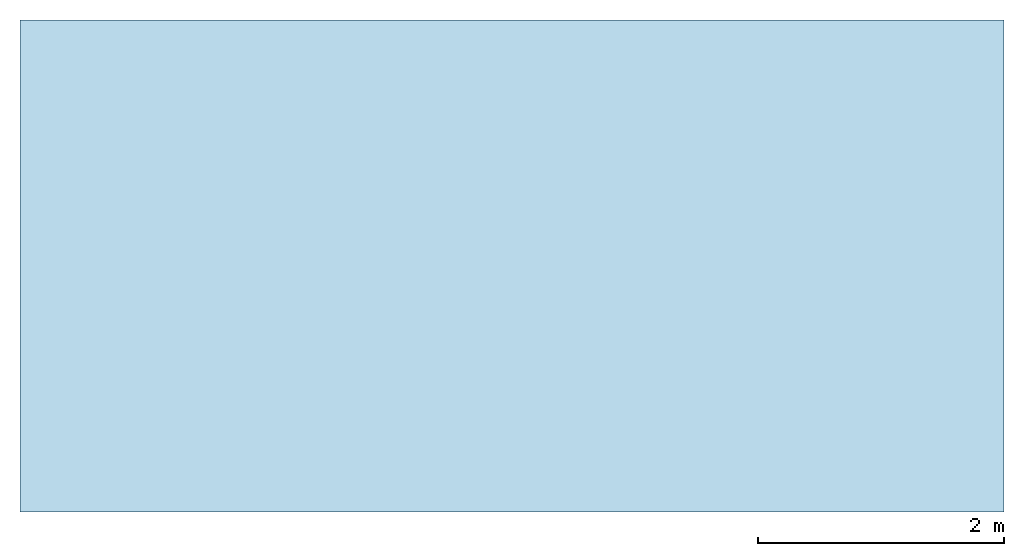
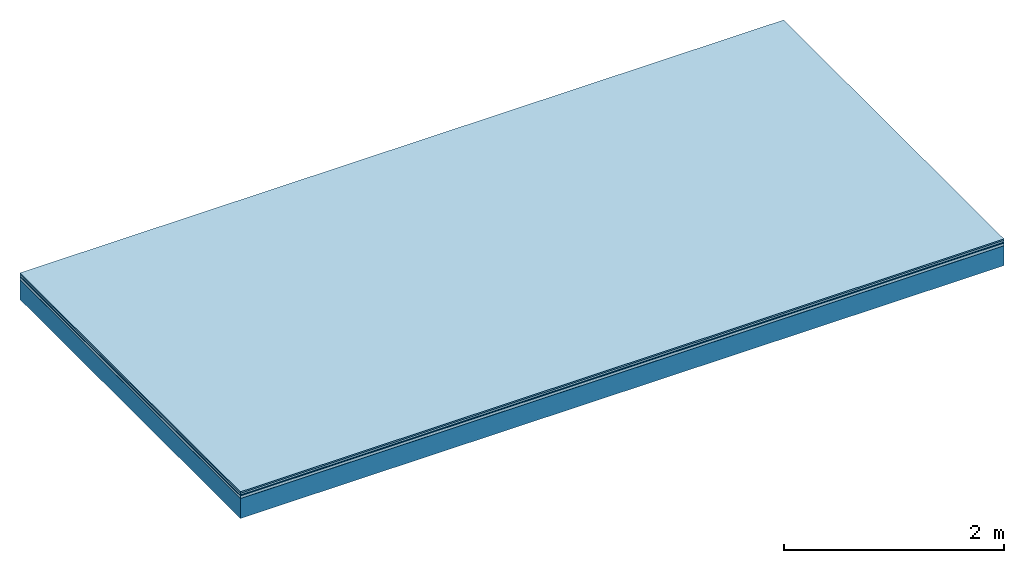
# One storey: 5 plates, 1 member, 1 element without a shape of its own.
"""IFC4 building model written with IfcOpenShell, lengths in metres."""

from ifc_helpers import new_model, si_unit, derived_unit, direction, frame, frame_2d, origin, origin_with_axes, place, context, project, spatial, rectangle, extrude, material, layer, layer_set, type_object, element, aggregate, save


model = new_model("IFC4")

# Units and contexts
plan_context = context("Plan", 3, precision=1e-05, world=origin(), true_north=direction((0.0, 1.0)))
model_context = context("Model", 3, precision=1e-05, world=origin(), true_north=direction((0.0, 1.0)))
ifc_project = project(units=[si_unit("LENGTHUNIT", "METRE"), derived_unit("SOUNDPRESSUREUNIT", [(si_unit("PRESSUREUNIT", "PASCAL", prefix="MICRO"), 0)]), si_unit("ENERGYUNIT", "JOULE", prefix="MEGA"), si_unit("MASSUNIT", "GRAM", prefix="KILO"), derived_unit("THERMALTRANSMITTANCEUNIT", [(si_unit("POWERUNIT", "WATT"), 1), (si_unit("AREAUNIT", "SQUARE_METRE"), -1), (si_unit("THERMODYNAMICTEMPERATUREUNIT", "KELVIN"), -1)]), derived_unit("AREADENSITYUNIT", [(si_unit("MASSUNIT", "GRAM", prefix="KILO"), 1), (si_unit("AREAUNIT", "SQUARE_METRE"), -1)]), derived_unit("USERDEFINED", [(si_unit("ENERGYUNIT", "JOULE", prefix="MEGA"), 1), (si_unit("AREAUNIT", "SQUARE_METRE"), -1)])], contexts=[plan_context, model_context])

# Site, building, storey
site = spatial("IfcSite", under=ifc_project)
building_placement = place(None, origin())
building = spatial("IfcBuilding", under=site, at=building_placement)
storey_placement = place(building_placement, origin())
storey = spatial("IfcBuildingStorey", under=building, at=storey_placement)

# Slab, member, plates
ifc_material_1 = material(Category="11.013")
ifc_layer_1 = layer(ifc_material_1, 0.015, Name="Flooring")
ifc_material_2 = material(Category="03.007")
ifc_layer_2 = layer(ifc_material_2, 0.02, Name="On-material")
ifc_material_3 = material(Name="Wood fiber generic product", Category="10.009")
ifc_layer_3 = layer(ifc_material_3, 0.01, Name="Impact sound insulation")
ifc_material_4 = material(Name="with broken")
ifc_layer_4 = layer(ifc_material_4, 0.03, Name="on Supporting structure")
ifc_material_5 = material(Name="protection", Category="09.007")
ifc_layer_5 = layer(ifc_material_5, 0.0005, Name="Sub-floor")
ifc_material_6 = material(Name="no composite action")
ifc_layer_6 = layer(ifc_material_6, 0.0, Name="Bond")
ifc_layer_7 = layer(None, 0.22, Name="Supporting structure")
ifc_layer_set = layer_set([ifc_layer_1, ifc_layer_2, ifc_layer_3, ifc_layer_4, ifc_layer_5, ifc_layer_6, ifc_layer_7])
slab_type = type_object("IfcSlabType", Name="A2047", PredefinedType="NOTDEFINED", material=ifc_layer_set)
slab_placement = place(None, frame((0.0, 0.0, 0.0), z_axis=(0.0, 0.0, -1.0), x_axis=(1.0, 0.0, 0.0)))
slab = element("IfcSlab", 1, at=slab_placement, inside=storey, type_object=slab_type, material=ifc_layer_set, Name="Slab #1")
ifc_material_7 = material(Name="Solid timber panel")
member_placement = place(slab_placement, origin())
member = element("IfcMember", 2, at=member_placement, material=ifc_material_7, Name="Supporting structure", context=plan_context, shape_type="SweptSolid", body=[
    extrude(rectangle(XDim=1.0, YDim=0.22, at=frame_2d((0.5, 0.11), x_axis=(1.0, 0.0))), frame((0.0, 4.0, 0.0755), z_axis=(0.0, -1.0, 0.0), x_axis=(1.0, 0.0, 0.0)), (0.0, 0.0, 1.0), 4.0),
    extrude(rectangle(XDim=1.0, YDim=0.22, at=frame_2d((0.5, 0.11), x_axis=(1.0, 0.0))), frame((1.0, 4.0, 0.0755), z_axis=(0.0, -1.0, 0.0), x_axis=(1.0, 0.0, 0.0)), (0.0, 0.0, 1.0), 4.0),
    extrude(rectangle(XDim=1.0, YDim=0.22, at=frame_2d((0.5, 0.11), x_axis=(1.0, 0.0))), frame((2.0, 4.0, 0.0755), z_axis=(0.0, -1.0, 0.0), x_axis=(1.0, 0.0, 0.0)), (0.0, 0.0, 1.0), 4.0),
    extrude(rectangle(XDim=1.0, YDim=0.22, at=frame_2d((0.5, 0.11), x_axis=(1.0, 0.0))), frame((3.0, 4.0, 0.0755), z_axis=(0.0, -1.0, 0.0), x_axis=(1.0, 0.0, 0.0)), (0.0, 0.0, 1.0), 4.0),
    extrude(rectangle(XDim=1.0, YDim=0.22, at=frame_2d((0.5, 0.11), x_axis=(1.0, 0.0))), frame((4.0, 4.0, 0.0755), z_axis=(0.0, -1.0, 0.0), x_axis=(1.0, 0.0, 0.0)), (0.0, 0.0, 1.0), 4.0),
    extrude(rectangle(XDim=1.0, YDim=0.22, at=frame_2d((0.5, 0.11), x_axis=(1.0, 0.0))), frame((5.0, 4.0, 0.0755), z_axis=(0.0, -1.0, 0.0), x_axis=(1.0, 0.0, 0.0)), (0.0, 0.0, 1.0), 4.0),
    extrude(rectangle(XDim=1.0, YDim=0.22, at=frame_2d((0.5, 0.11), x_axis=(1.0, 0.0))), frame((6.0, 4.0, 0.0755), z_axis=(0.0, -1.0, 0.0), x_axis=(1.0, 0.0, 0.0)), (0.0, 0.0, 1.0), 4.0),
    extrude(rectangle(XDim=1.0, YDim=0.22, at=frame_2d((0.5, 0.11), x_axis=(1.0, 0.0))), frame((7.0, 4.0, 0.0755), z_axis=(0.0, -1.0, 0.0), x_axis=(1.0, 0.0, 0.0)), (0.0, 0.0, 1.0), 4.0),
])
plate_1_placement = place(slab_placement, origin())
plate_1 = element("IfcPlate", 3, at=plate_1_placement, material=ifc_material_1, Name="Flooring", context=plan_context, shape_type="SweptSolid", body=[
    extrude(rectangle(XDim=8.0, YDim=4.0, at=frame_2d((4.0, 2.0), x_axis=(1.0, 0.0))), origin_with_axes(), (0.0, 0.0, 1.0), 0.015),
])
plate_2_placement = place(slab_placement, origin())
plate_2 = element("IfcPlate", 4, at=plate_2_placement, material=ifc_material_2, Name="On-material", context=plan_context, shape_type="SweptSolid", body=[
    extrude(rectangle(XDim=8.0, YDim=4.0, at=frame_2d((4.0, 2.0), x_axis=(1.0, 0.0))), frame((0.0, 0.0, 0.015), z_axis=(0.0, 0.0, 1.0), x_axis=(1.0, 0.0, 0.0)), (0.0, 0.0, 1.0), 0.02),
])
plate_3_placement = place(slab_placement, origin())
plate_3 = element("IfcPlate", 5, at=plate_3_placement, material=ifc_material_3, Name="Impact sound insulation", context=plan_context, shape_type="SweptSolid", body=[
    extrude(rectangle(XDim=8.0, YDim=4.0, at=frame_2d((4.0, 2.0), x_axis=(1.0, 0.0))), frame((0.0, 0.0, 0.035), z_axis=(0.0, 0.0, 1.0), x_axis=(1.0, 0.0, 0.0)), (0.0, 0.0, 1.0), 0.01),
])
plate_4_placement = place(slab_placement, origin())
plate_4 = element("IfcPlate", 6, at=plate_4_placement, material=ifc_material_4, Name="on Supporting structure", context=plan_context, shape_type="SweptSolid", body=[
    extrude(rectangle(XDim=8.0, YDim=4.0, at=frame_2d((4.0, 2.0), x_axis=(1.0, 0.0))), frame((0.0, 0.0, 0.045), z_axis=(0.0, 0.0, 1.0), x_axis=(1.0, 0.0, 0.0)), (0.0, 0.0, 1.0), 0.03),
])
plate_5_placement = place(slab_placement, origin())
plate_5 = element("IfcPlate", 7, at=plate_5_placement, material=ifc_material_5, Name="Sub-floor", context=plan_context, shape_type="SweptSolid", body=[
    extrude(rectangle(XDim=8.0, YDim=4.0, at=frame_2d((4.0, 2.0), x_axis=(1.0, 0.0))), frame((0.0, 0.0, 0.075), z_axis=(0.0, 0.0, 1.0), x_axis=(1.0, 0.0, 0.0)), (0.0, 0.0, 1.0), 0.0005),
])
aggregate(slab, [plate_1, plate_2, plate_3, plate_4, plate_5, member])

save(model, "model.ifc")
